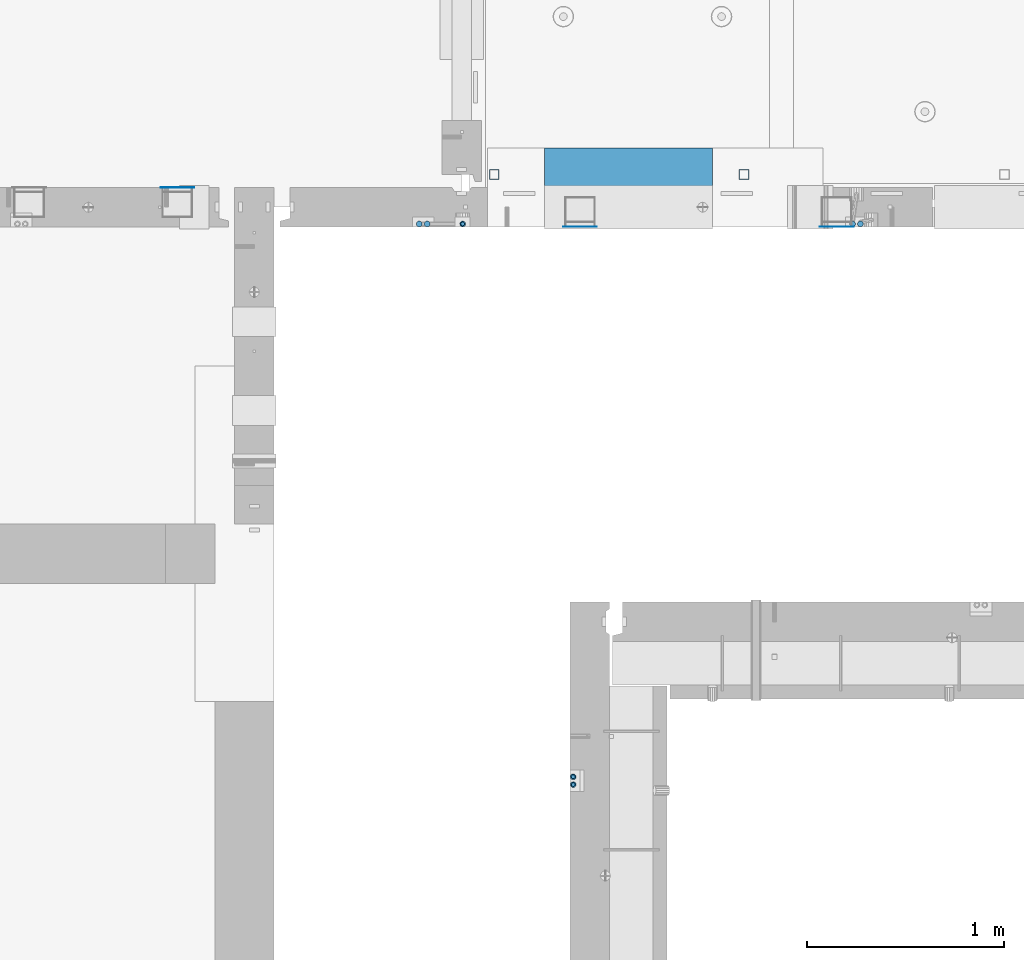
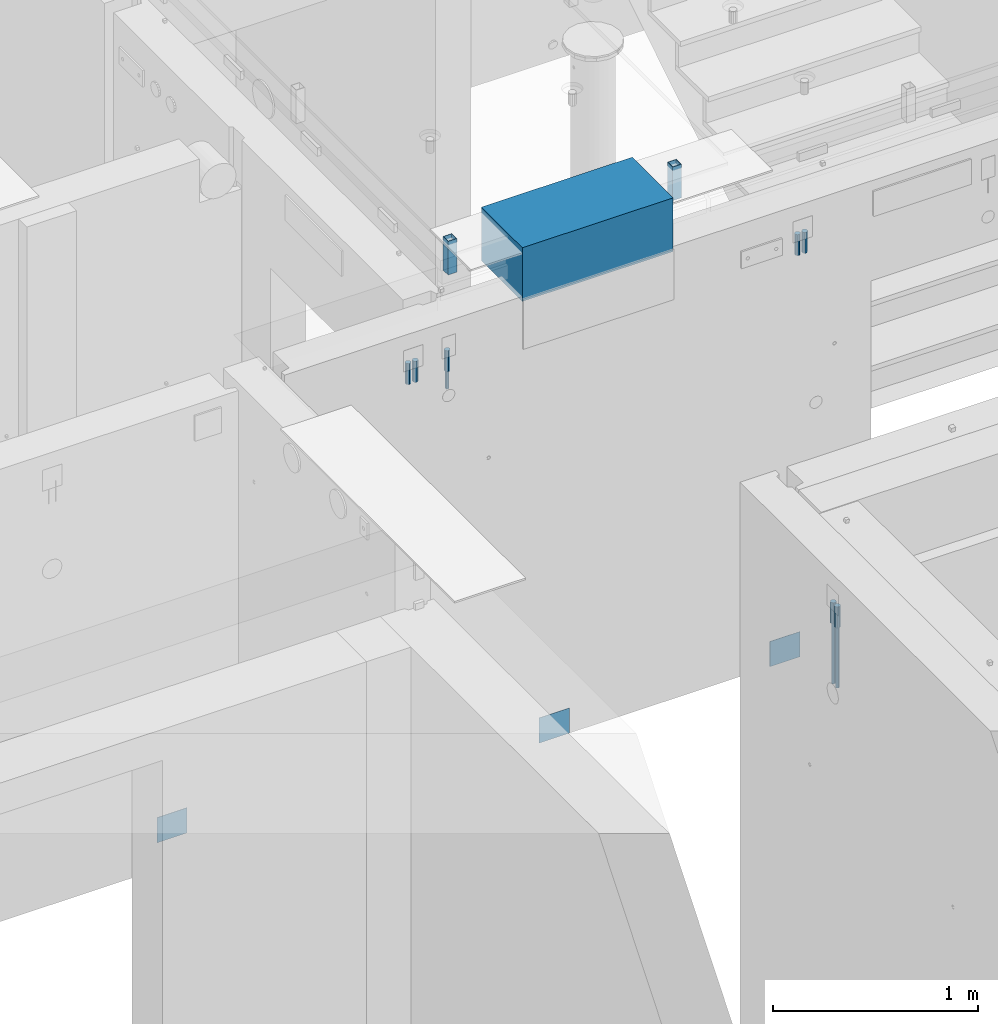
# One storey, part 8 of 264: 16 columns, 10 elements without a shape of their own.
"""IFC2X3 building model written with IfcOpenShell, lengths in millimetres."""

from ifc_helpers import new_model, si_unit, frame, origin_with_axes, place, context, subcontext, project, spatial, faceted_brep, material, type_object, element, aggregate, save


model = new_model("IFC2X3")

# Units and contexts
model_context = context("Model", 3, precision=1e-05, world=origin_with_axes())
body_context = subcontext(model_context, "Body", "Model", "MODEL_VIEW")
ifc_project = project(units=[si_unit("LENGTHUNIT", "METRE", prefix="MILLI"), si_unit("AREAUNIT", "SQUARE_METRE"), si_unit("VOLUMEUNIT", "CUBIC_METRE"), si_unit("MASSUNIT", "GRAM", prefix="KILO"), si_unit("TIMEUNIT", "SECOND"), si_unit("PLANEANGLEUNIT", "RADIAN"), si_unit("SOLIDANGLEUNIT", "STERADIAN"), si_unit("THERMODYNAMICTEMPERATUREUNIT", "DEGREE_CELSIUS"), si_unit("LUMINOUSINTENSITYUNIT", "LUMEN")], contexts=[model_context])

# Site, building, storey
site_placement = place(None, origin_with_axes())
site = spatial("IfcSite", under=ifc_project, at=site_placement, CompositionType="ELEMENT")
building_placement = place(site_placement, origin_with_axes())
building = spatial("IfcBuilding", under=site, at=building_placement, CompositionType="ELEMENT")
storey_placement = place(building_placement, origin_with_axes())
storey = spatial("IfcBuildingStorey", under=building, at=storey_placement, Name="K", CompositionType="ELEMENT", Elevation=0.0)

# Assembly, columns
assembly_1_placement = place(storey_placement, origin_with_axes())
assembly_1 = element("IfcElementAssembly", 1, at=assembly_1_placement, inside=storey, AssemblyPlace="NOTDEFINED", PredefinedType="REINFORCEMENT_UNIT")
ifc_material_1 = material()
column_type_1 = type_object("IfcColumnType", Name="D30", PredefinedType="NOTDEFINED")
column_1_placement = place(assembly_1_placement, frame((19730.0015915468, 15095.0, 81167.5), z_axis=(0.0, 1.0, 0.0), x_axis=(0.0, 0.0, 1.0)))
column_1 = element("IfcColumn", 2, at=column_1_placement, type_object=column_type_1, material=ifc_material_1, ObjectType="D30", context=body_context, shape_type="Brep", body=[
    faceted_brep([(0.0, -15.0, 0.0), (0.0, -12.9903810567666, -7.5), (125.0, -12.9903810567666, -7.5), (125.0, -15.0, 0.0), (0.0, -7.5, -12.9903810567666), (125.0, -7.5, -12.9903810567666), (0.0, 0.0, -15.0), (125.0, 0.0, -15.0), (0.0, 7.5, -12.9903810567666), (125.0, 7.5, -12.9903810567666), (0.0, 12.9903810567666, -7.5), (125.0, 12.9903810567666, -7.5), (0.0, 15.0, 0.0), (125.0, 15.0, 0.0), (0.0, 12.9903810567666, 7.5), (125.0, 12.9903810567666, 7.5), (0.0, 7.5, 12.9903810567666), (125.0, 7.5, 12.9903810567666), (0.0, 0.0, 15.0), (125.0, 0.0, 15.0), (0.0, -7.5, 12.9903810567666), (125.0, -7.5, 12.9903810567666), (0.0, -12.9903810567666, 7.5), (125.0, -12.9903810567666, 7.5)], [[[0, 1, 2, 3]], [[1, 4, 5, 2]], [[4, 6, 7, 5]], [[6, 8, 9, 7]], [[8, 10, 11, 9]], [[10, 12, 13, 11]], [[12, 14, 15, 13]], [[14, 16, 17, 15]], [[16, 18, 19, 17]], [[18, 20, 21, 19]], [[20, 22, 23, 21]], [[22, 0, 3, 23]], [[5, 7, 9, 11, 13, 15, 17, 19, 21, 23, 3, 2]], [[22, 20, 18, 16, 14, 12, 10, 8, 6, 4, 1, 0]]]),
])
column_2_placement = place(assembly_1_placement, frame((19690.0015915468, 15095.0, 81167.5), z_axis=(0.0, 1.0, 0.0), x_axis=(0.0, 0.0, 1.0)))
column_2 = element("IfcColumn", 3, at=column_2_placement, type_object=column_type_1, material=ifc_material_1, ObjectType="D30", context=body_context, shape_type="Brep", body=[
    faceted_brep([(0.0, -15.0, 0.0), (0.0, -12.9903810567666, -7.5), (125.0, -12.9903810567666, -7.5), (125.0, -15.0, 0.0), (0.0, -7.5, -12.9903810567666), (125.0, -7.5, -12.9903810567666), (0.0, 0.0, -15.0), (125.0, 0.0, -15.0), (0.0, 7.5, -12.9903810567666), (125.0, 7.5, -12.9903810567666), (0.0, 12.9903810567666, -7.5), (125.0, 12.9903810567666, -7.5), (0.0, 15.0, 0.0), (125.0, 15.0, 0.0), (0.0, 12.9903810567666, 7.5), (125.0, 12.9903810567666, 7.5), (0.0, 7.5, 12.9903810567666), (125.0, 7.5, 12.9903810567666), (0.0, 0.0, 15.0), (125.0, 0.0, 15.0), (0.0, -7.5, 12.9903810567666), (125.0, -7.5, 12.9903810567666), (0.0, -12.9903810567666, 7.5), (125.0, -12.9903810567666, 7.5)], [[[0, 1, 2, 3]], [[1, 4, 5, 2]], [[4, 6, 7, 5]], [[6, 8, 9, 7]], [[8, 10, 11, 9]], [[10, 12, 13, 11]], [[12, 14, 15, 13]], [[14, 16, 17, 15]], [[16, 18, 19, 17]], [[18, 20, 21, 19]], [[20, 22, 23, 21]], [[22, 0, 3, 23]], [[5, 7, 9, 11, 13, 15, 17, 19, 21, 23, 3, 2]], [[22, 20, 18, 16, 14, 12, 10, 8, 6, 4, 1, 0]]]),
])
column_3_placement = place(assembly_1_placement, frame((17715.0015915468, 15095.0, 81167.5), z_axis=(0.0, 1.0, 0.0), x_axis=(0.0, 0.0, 1.0)))
column_3 = element("IfcColumn", 4, at=column_3_placement, type_object=column_type_1, material=ifc_material_1, ObjectType="D30", context=body_context, shape_type="Brep", body=[
    faceted_brep([(0.0, -15.0, 0.0), (0.0, -12.9903810567666, -7.5), (125.0, -12.9903810567666, -7.5), (125.0, -15.0, 0.0), (0.0, -7.5, -12.9903810567666), (125.0, -7.5, -12.9903810567666), (0.0, 0.0, -15.0), (125.0, 0.0, -15.0), (0.0, 7.5, -12.9903810567666), (125.0, 7.5, -12.9903810567666), (0.0, 12.9903810567666, -7.5), (125.0, 12.9903810567666, -7.5), (0.0, 15.0, 0.0), (125.0, 15.0, 0.0), (0.0, 12.9903810567666, 7.5), (125.0, 12.9903810567666, 7.5), (0.0, 7.5, 12.9903810567666), (125.0, 7.5, 12.9903810567666), (0.0, 0.0, 15.0), (125.0, 0.0, 15.0), (0.0, -7.5, 12.9903810567666), (125.0, -7.5, 12.9903810567666), (0.0, -12.9903810567666, 7.5), (125.0, -12.9903810567666, 7.5)], [[[0, 1, 2, 3]], [[1, 4, 5, 2]], [[4, 6, 7, 5]], [[6, 8, 9, 7]], [[8, 10, 11, 9]], [[10, 12, 13, 11]], [[12, 14, 15, 13]], [[14, 16, 17, 15]], [[16, 18, 19, 17]], [[18, 20, 21, 19]], [[20, 22, 23, 21]], [[22, 0, 3, 23]], [[5, 7, 9, 11, 13, 15, 17, 19, 21, 23, 3, 2]], [[22, 20, 18, 16, 14, 12, 10, 8, 6, 4, 1, 0]]]),
])
column_4_placement = place(assembly_1_placement, frame((17535.0015915468, 15095.0, 81167.5), z_axis=(0.0, 1.0, 0.0), x_axis=(0.0, 0.0, 1.0)))
column_4 = element("IfcColumn", 5, at=column_4_placement, type_object=column_type_1, material=ifc_material_1, ObjectType="D30", context=body_context, shape_type="Brep", body=[
    faceted_brep([(0.0, -15.0, 0.0), (0.0, -12.9903810567666, -7.5), (125.0, -12.9903810567666, -7.5), (125.0, -15.0, 0.0), (0.0, -7.5, -12.9903810567666), (125.0, -7.5, -12.9903810567666), (0.0, 0.0, -15.0), (125.0, 0.0, -15.0), (0.0, 7.5, -12.9903810567666), (125.0, 7.5, -12.9903810567666), (0.0, 12.9903810567666, -7.5), (125.0, 12.9903810567666, -7.5), (0.0, 15.0, 0.0), (125.0, 15.0, 0.0), (0.0, 12.9903810567666, 7.5), (125.0, 12.9903810567666, 7.5), (0.0, 7.5, 12.9903810567666), (125.0, 7.5, 12.9903810567666), (0.0, 0.0, 15.0), (125.0, 0.0, 15.0), (0.0, -7.5, 12.9903810567666), (125.0, -7.5, 12.9903810567666), (0.0, -12.9903810567666, 7.5), (125.0, -12.9903810567666, 7.5)], [[[0, 1, 2, 3]], [[1, 4, 5, 2]], [[4, 6, 7, 5]], [[6, 8, 9, 7]], [[8, 10, 11, 9]], [[10, 12, 13, 11]], [[12, 14, 15, 13]], [[14, 16, 17, 15]], [[16, 18, 19, 17]], [[18, 20, 21, 19]], [[20, 22, 23, 21]], [[22, 0, 3, 23]], [[5, 7, 9, 11, 13, 15, 17, 19, 21, 23, 3, 2]], [[22, 20, 18, 16, 14, 12, 10, 8, 6, 4, 1, 0]]]),
])
column_5_placement = place(assembly_1_placement, frame((17495.0015915468, 15095.0, 81167.5), z_axis=(0.0, 1.0, 0.0), x_axis=(0.0, 0.0, 1.0)))
column_5 = element("IfcColumn", 6, at=column_5_placement, type_object=column_type_1, material=ifc_material_1, ObjectType="D30", context=body_context, shape_type="Brep", body=[
    faceted_brep([(0.0, -15.0, 0.0), (0.0, -12.9903810567666, -7.5), (125.0, -12.9903810567666, -7.5), (125.0, -15.0, 0.0), (0.0, -7.5, -12.9903810567666), (125.0, -7.5, -12.9903810567666), (0.0, 0.0, -15.0), (125.0, 0.0, -15.0), (0.0, 7.5, -12.9903810567666), (125.0, 7.5, -12.9903810567666), (0.0, 12.9903810567666, -7.5), (125.0, 12.9903810567666, -7.5), (0.0, 15.0, 0.0), (125.0, 15.0, 0.0), (0.0, 12.9903810567666, 7.5), (125.0, 12.9903810567666, 7.5), (0.0, 7.5, 12.9903810567666), (125.0, 7.5, 12.9903810567666), (0.0, 0.0, 15.0), (125.0, 0.0, 15.0), (0.0, -7.5, 12.9903810567666), (125.0, -7.5, 12.9903810567666), (0.0, -12.9903810567666, 7.5), (125.0, -12.9903810567666, 7.5)], [[[0, 1, 2, 3]], [[1, 4, 5, 2]], [[4, 6, 7, 5]], [[6, 8, 9, 7]], [[8, 10, 11, 9]], [[10, 12, 13, 11]], [[12, 14, 15, 13]], [[14, 16, 17, 15]], [[16, 18, 19, 17]], [[18, 20, 21, 19]], [[20, 22, 23, 21]], [[22, 0, 3, 23]], [[5, 7, 9, 11, 13, 15, 17, 19, 21, 23, 3, 2]], [[22, 20, 18, 16, 14, 12, 10, 8, 6, 4, 1, 0]]]),
])

assembly_2_placement = place(storey_placement, origin_with_axes())
assembly_2 = element("IfcElementAssembly", 7, at=assembly_2_placement, inside=storey, AssemblyPlace="NOTDEFINED", PredefinedType="REINFORCEMENT_UNIT")
column_6_placement = place(assembly_2_placement, frame((18275.0, 12255.000305038, 81167.5), z_axis=(1.0, 0.0, 0.0), x_axis=(0.0, 0.0, 1.0)))
column_6 = element("IfcColumn", 8, at=column_6_placement, type_object=column_type_1, material=ifc_material_1, ObjectType="D30", context=body_context, shape_type="Brep", body=[
    faceted_brep([(0.0, -15.0, 0.0), (0.0, -12.9903810567666, -7.5), (125.0, -12.9903810567666, -7.5), (125.0, -15.0, 0.0), (0.0, -7.5, -12.9903810567666), (125.0, -7.5, -12.9903810567666), (0.0, 0.0, -15.0), (125.0, 0.0, -15.0), (0.0, 7.5, -12.9903810567666), (125.0, 7.5, -12.9903810567666), (0.0, 12.9903810567666, -7.5), (125.0, 12.9903810567666, -7.5), (0.0, 15.0, 0.0), (125.0, 15.0, 0.0), (0.0, 12.9903810567666, 7.5), (125.0, 12.9903810567666, 7.5), (0.0, 7.5, 12.9903810567666), (125.0, 7.5, 12.9903810567666), (0.0, 0.0, 15.0), (125.0, 0.0, 15.0), (0.0, -7.5, 12.9903810567666), (125.0, -7.5, 12.9903810567666), (0.0, -12.9903810567666, 7.5), (125.0, -12.9903810567666, 7.5)], [[[0, 1, 2, 3]], [[1, 4, 5, 2]], [[4, 6, 7, 5]], [[6, 8, 9, 7]], [[8, 10, 11, 9]], [[10, 12, 13, 11]], [[12, 14, 15, 13]], [[14, 16, 17, 15]], [[16, 18, 19, 17]], [[18, 20, 21, 19]], [[20, 22, 23, 21]], [[22, 0, 3, 23]], [[5, 7, 9, 11, 13, 15, 17, 19, 21, 23, 3, 2]], [[22, 20, 18, 16, 14, 12, 10, 8, 6, 4, 1, 0]]]),
])
column_7_placement = place(assembly_2_placement, frame((18275.0, 12295.000305038, 81167.5), z_axis=(1.0, 0.0, 0.0), x_axis=(0.0, 0.0, 1.0)))
column_7 = element("IfcColumn", 9, at=column_7_placement, type_object=column_type_1, material=ifc_material_1, ObjectType="D30", context=body_context, shape_type="Brep", body=[
    faceted_brep([(0.0, -15.0, 0.0), (0.0, -12.9903810567666, -7.5), (125.0, -12.9903810567666, -7.5), (125.0, -15.0, 0.0), (0.0, -7.5, -12.9903810567666), (125.0, -7.5, -12.9903810567666), (0.0, 0.0, -15.0), (125.0, 0.0, -15.0), (0.0, 7.5, -12.9903810567666), (125.0, 7.5, -12.9903810567666), (0.0, 12.9903810567666, -7.5), (125.0, 12.9903810567666, -7.5), (0.0, 15.0, 0.0), (125.0, 15.0, 0.0), (0.0, 12.9903810567666, 7.5), (125.0, 12.9903810567666, 7.5), (0.0, 7.5, 12.9903810567666), (125.0, 7.5, 12.9903810567666), (0.0, 0.0, 15.0), (125.0, 0.0, 15.0), (0.0, -7.5, 12.9903810567666), (125.0, -7.5, 12.9903810567666), (0.0, -12.9903810567666, 7.5), (125.0, -12.9903810567666, 7.5)], [[[0, 1, 2, 3]], [[1, 4, 5, 2]], [[4, 6, 7, 5]], [[6, 8, 9, 7]], [[8, 10, 11, 9]], [[10, 12, 13, 11]], [[12, 14, 15, 13]], [[14, 16, 17, 15]], [[16, 18, 19, 17]], [[18, 20, 21, 19]], [[20, 22, 23, 21]], [[22, 0, 3, 23]], [[5, 7, 9, 11, 13, 15, 17, 19, 21, 23, 3, 2]], [[22, 20, 18, 16, 14, 12, 10, 8, 6, 4, 1, 0]]]),
])

# Assembly, column
assembly_3_placement = place(assembly_1_placement, origin_with_axes())
assembly_3 = element("IfcElementAssembly", 10, at=assembly_3_placement, Name="Steel Assembly", AssemblyPlace="NOTDEFINED", PredefinedType="NOTDEFINED")
ifc_material_2 = material(Name="Undefined")
column_type_2 = type_object("IfcColumnType", PredefinedType="NOTDEFINED")
column_8_placement = place(assembly_3_placement, frame((18309.9991455078, 15080.9999974657, 78775.0000025593), z_axis=(0.0, -1.0, 0.0), x_axis=(0.0, 0.0, 1.0)))
column_8 = element("IfcColumn", 11, at=column_8_placement, type_object=column_type_2, material=ifc_material_2, Name="SPK3", context=body_context, shape_type="Brep", body=[
    faceted_brep([(0.0, 85.0, -1.0), (0.0, 85.0, 1.0), (150.0, 85.0, 1.0), (150.0, 85.0, -1.0), (0.0, -85.0, 1.0), (150.0, -85.0, 1.0), (0.0, -85.0, -1.0), (150.0, -85.0, -1.0)], [[[0, 1, 2, 3]], [[1, 4, 5, 2]], [[4, 6, 7, 5]], [[6, 0, 3, 7]], [[5, 7, 3, 2]], [[6, 4, 1, 0]]]),
])
aggregate(assembly_3, [column_8])

# Assemblies, column
assembly_4_placement = place(storey_placement, origin_with_axes())
assembly_4 = element("IfcElementAssembly", 12, at=assembly_4_placement, inside=storey, AssemblyPlace="NOTDEFINED", PredefinedType="REINFORCEMENT_UNIT")
assembly_5_placement = place(assembly_4_placement, origin_with_axes())
assembly_5 = element("IfcElementAssembly", 13, at=assembly_5_placement, Name="Steel Assembly", AssemblyPlace="NOTDEFINED", PredefinedType="NOTDEFINED")
aggregate(assembly_4, [assembly_5])
column_9_placement = place(assembly_5_placement, frame((16270.0012172342, 15279.0002441207, 78775.1200050936), z_axis=(0.0, 1.0, 0.0), x_axis=(0.0, 0.0, 1.0)))
column_9 = element("IfcColumn", 14, at=column_9_placement, type_object=column_type_2, material=ifc_material_2, Name="SPK3", context=body_context, shape_type="Brep", body=[
    faceted_brep([(0.0, 85.0, -1.0), (0.0, 85.0, 1.0), (150.0, 85.0, 1.0), (150.0, 85.0, -1.0), (0.0, -85.0, 1.0), (150.0, -85.0, 1.0), (0.0, -85.0, -1.0), (150.0, -85.0, -1.0)], [[[0, 1, 2, 3]], [[1, 4, 5, 2]], [[4, 6, 7, 5]], [[6, 0, 3, 7]], [[5, 7, 3, 2]], [[6, 4, 1, 0]]]),
])
aggregate(assembly_5, [column_9])

# Assembly, column
assembly_6_placement = place(assembly_1_placement, origin_with_axes())
assembly_6 = element("IfcElementAssembly", 15, at=assembly_6_placement, Name="Steel Assembly", AssemblyPlace="NOTDEFINED", PredefinedType="NOTDEFINED")
column_10_placement = place(assembly_6_placement, frame((19609.9991455078, 15080.9999974657, 78775.0000025593), z_axis=(0.0, -1.0, 0.0), x_axis=(0.0, 0.0, 1.0)))
column_10 = element("IfcColumn", 16, at=column_10_placement, type_object=column_type_2, material=ifc_material_2, Name="SPK3", context=body_context, shape_type="Brep", body=[
    faceted_brep([(0.0, 85.0, -1.0), (0.0, 85.0, 1.0), (150.0, 85.0, 1.0), (150.0, 85.0, -1.0), (0.0, -85.0, 1.0), (150.0, -85.0, 1.0), (0.0, -85.0, -1.0), (150.0, -85.0, -1.0)], [[[0, 1, 2, 3]], [[1, 4, 5, 2]], [[4, 6, 7, 5]], [[6, 0, 3, 7]], [[5, 7, 3, 2]], [[6, 4, 1, 0]]]),
])
aggregate(assembly_6, [column_10])

# Assemblies, columns
assembly_7_placement = place(storey_placement, origin_with_axes())
assembly_7 = element("IfcElementAssembly", 17, at=assembly_7_placement, inside=storey, AssemblyPlace="NOTDEFINED", PredefinedType="REINFORCEMENT_UNIT")
assembly_8_placement = place(assembly_7_placement, origin_with_axes())
assembly_8 = element("IfcElementAssembly", 18, at=assembly_8_placement, Name="Steel Assembly", AssemblyPlace="NOTDEFINED", PredefinedType="RIGID_FRAME")
ifc_material_3 = material(Name="STEEL/S355J2")
column_type_3 = type_object("IfcColumnType", Name="50X50X3", PredefinedType="NOTDEFINED")
column_11_placement = place(assembly_8_placement, frame((17875.0159390845, 15345.0026483099, 81550.0), z_axis=(-1.0, 3.00000001838171e-08, 0.0), x_axis=(0.0, 0.0, 1.0)))
column_11 = element("IfcColumn", 19, at=column_11_placement, type_object=column_type_3, material=ifc_material_3, ObjectType="50X50X3", context=body_context, shape_type="Brep", body=[
    faceted_brep([(0.0, 22.0, -22.0), (0.0, -22.0, -22.0), (200.0, -22.0, -22.0), (200.0, 22.0, -22.0), (0.0, -22.0, 22.0), (200.0, -22.0, 22.0), (0.0, 22.0, 22.0), (200.0, 22.0, 22.0), (0.0, 25.0, -25.0), (0.0, 25.0, 25.0), (200.0, 25.0, 25.0), (200.0, 25.0, -25.0), (0.0, -25.0, 25.0), (200.0, -25.0, 25.0), (0.0, -25.0, -25.0), (200.0, -25.0, -25.0)], [[[0, 1, 2, 3]], [[1, 4, 5, 2]], [[4, 6, 7, 5]], [[6, 0, 3, 7]], [[8, 9, 10, 11]], [[9, 12, 13, 10]], [[12, 14, 15, 13]], [[14, 8, 11, 15]], [[13, 15, 11, 10], [5, 7, 3, 2]], [[14, 12, 9, 8], [6, 4, 1, 0]]]),
])
aggregate(assembly_8, [column_11])
assembly_9_placement = place(assembly_7_placement, origin_with_axes())
assembly_9 = element("IfcElementAssembly", 20, at=assembly_9_placement, Name="Steel Assembly", AssemblyPlace="NOTDEFINED", PredefinedType="RIGID_FRAME")
aggregate(assembly_7, [assembly_8, assembly_9])
column_12_placement = place(assembly_9_placement, frame((19140.0159390845, 15345.0026483099, 81550.0), z_axis=(-1.0, 3.00000001838171e-08, 0.0), x_axis=(0.0, 0.0, 1.0)))
column_12 = element("IfcColumn", 21, at=column_12_placement, type_object=column_type_3, material=ifc_material_3, ObjectType="50X50X3", context=body_context, shape_type="Brep", body=[
    faceted_brep([(0.0, 22.0, -22.0), (0.0, -22.0, -22.0), (200.0, -22.0, -22.0), (200.0, 22.0, -22.0), (0.0, -22.0, 22.0), (200.0, -22.0, 22.0), (0.0, 22.0, 22.0), (200.0, 22.0, 22.0), (0.0, 25.0, -25.0), (0.0, 25.0, 25.0), (200.0, 25.0, 25.0), (200.0, 25.0, -25.0), (0.0, -25.0, 25.0), (200.0, -25.0, 25.0), (0.0, -25.0, -25.0), (200.0, -25.0, -25.0)], [[[0, 1, 2, 3]], [[1, 4, 5, 2]], [[4, 6, 7, 5]], [[6, 0, 3, 7]], [[8, 9, 10, 11]], [[9, 12, 13, 10]], [[12, 14, 15, 13]], [[14, 8, 11, 15]], [[13, 15, 11, 10], [5, 7, 3, 2]], [[14, 12, 9, 8], [6, 4, 1, 0]]]),
])
aggregate(assembly_9, [column_12])

# Column
column_type_4 = type_object("IfcColumnType", Name="D20", PredefinedType="NOTDEFINED")
column_13_placement = place(assembly_1_placement, frame((17715.0015915473, 15095.0, 81060.0), z_axis=(0.0, 1.0, 0.0), x_axis=(0.0, 0.0, 1.0)))
column_13 = element("IfcColumn", 22, at=column_13_placement, type_object=column_type_4, material=ifc_material_1, Name="JM20", ObjectType="D20", context=body_context, shape_type="Brep", body=[
    faceted_brep([(0.0, -10.0, 0.0), (-4.19531716033816e-08, -7.07106781186667, -7.07106781187031), (107.499999999141, -7.07106781186667, -7.07106781186485), (107.499999999141, -10.0, 0.0), (0.0, 0.0, -10.0), (107.499999999141, 0.0, -10.0), (4.196772351861e-08, 7.07106781186303, -7.07106781186667), (107.499999999141, 7.07106781186667, -7.07106781186485), (0.0, 10.0, 0.0), (107.499999999141, 10.0, 0.0), (4.196772351861e-08, 7.07106781185939, 7.07106781185939), (107.499999999141, 7.07106781186667, 7.07106781186485), (0.0, 0.0, 10.0), (107.499999999141, 0.0, 10.0), (-4.19531716033816e-08, -7.07106781187031, 7.07106781185939), (107.499999999141, -7.07106781186667, 7.07106781186485)], [[[0, 1, 2, 3]], [[1, 4, 5, 2]], [[4, 6, 7, 5]], [[6, 8, 9, 7]], [[8, 10, 11, 9]], [[10, 12, 13, 11]], [[12, 14, 15, 13]], [[14, 0, 3, 15]], [[5, 7, 9, 11, 13, 15, 3, 2]], [[14, 12, 10, 8, 6, 4, 1, 0]]]),
])

aggregate(assembly_1, [column_1, column_2, column_13, column_3, column_4, column_5, assembly_3, assembly_6])

column_14_placement = place(assembly_2_placement, frame((18275.0, 12255.0003050374, 80805.0), z_axis=(1.0, 0.0, 0.0), x_axis=(0.0, 0.0, 1.0)))
column_14 = element("IfcColumn", 23, at=column_14_placement, type_object=column_type_4, material=ifc_material_1, Name="JM20", ObjectType="D20", context=body_context, shape_type="Brep", body=[
    faceted_brep([(0.0, -10.0, 0.0), (-4.19531716033816e-08, -7.07106781186667, -7.07106781187031), (362.5, -7.07106781186667, -7.07106781186485), (362.5, -10.0, 0.0), (0.0, 0.0, -10.0), (362.5, 0.0, -10.0), (4.196772351861e-08, 7.07106781186303, -7.07106781186667), (362.5, 7.07106781186667, -7.07106781186485), (0.0, 10.0, 0.0), (362.5, 10.0, 0.0), (4.196772351861e-08, 7.07106781185939, 7.07106781185939), (362.5, 7.07106781186667, 7.07106781186485), (0.0, 0.0, 10.0), (362.5, 0.0, 10.0), (-4.19531716033816e-08, -7.07106781187031, 7.07106781185939), (362.5, -7.07106781186667, 7.07106781186485)], [[[0, 1, 2, 3]], [[1, 4, 5, 2]], [[4, 6, 7, 5]], [[6, 8, 9, 7]], [[8, 10, 11, 9]], [[10, 12, 13, 11]], [[12, 14, 15, 13]], [[14, 0, 3, 15]], [[5, 7, 9, 11, 13, 15, 3, 2]], [[14, 12, 10, 8, 6, 4, 1, 0]]]),
])

column_15_placement = place(assembly_2_placement, frame((18275.0, 12295.0003050374, 80805.0), z_axis=(1.0, 0.0, 0.0), x_axis=(0.0, 0.0, 1.0)))
column_15 = element("IfcColumn", 24, at=column_15_placement, type_object=column_type_4, material=ifc_material_1, Name="JM20", ObjectType="D20", context=body_context, shape_type="Brep", body=[
    faceted_brep([(0.0, -10.0, 0.0), (-4.19531716033816e-08, -7.07106781186667, -7.07106781187031), (362.5, -7.07106781186667, -7.07106781186485), (362.5, -10.0, 0.0), (0.0, 0.0, -10.0), (362.5, 0.0, -10.0), (4.196772351861e-08, 7.07106781186303, -7.07106781186667), (362.5, 7.07106781186667, -7.07106781186485), (0.0, 10.0, 0.0), (362.5, 10.0, 0.0), (4.196772351861e-08, 7.07106781185939, 7.07106781185939), (362.5, 7.07106781186667, 7.07106781186485), (0.0, 0.0, 10.0), (362.5, 0.0, 10.0), (-4.19531716033816e-08, -7.07106781187031, 7.07106781185939), (362.5, -7.07106781186667, 7.07106781186485)], [[[0, 1, 2, 3]], [[1, 4, 5, 2]], [[4, 6, 7, 5]], [[6, 8, 9, 7]], [[8, 10, 11, 9]], [[10, 12, 13, 11]], [[12, 14, 15, 13]], [[14, 0, 3, 15]], [[5, 7, 9, 11, 13, 15, 3, 2]], [[14, 12, 10, 8, 6, 4, 1, 0]]]),
])

aggregate(assembly_2, [column_14, column_6, column_15, column_7])

# Assembly, column
assembly_10_placement = place(storey_placement, origin_with_axes())
assembly_10 = element("IfcElementAssembly", 25, at=assembly_10_placement, inside=storey, Name="Steel Assembly", AssemblyPlace="NOTDEFINED", PredefinedType="NOTDEFINED")
ifc_material_4 = material()
column_type_5 = type_object("IfcColumnType", PredefinedType="NOTDEFINED")
column_16_placement = place(assembly_10_placement, frame((18554.999845922, 15279.9995407462, 81440.0), z_axis=(0.0, 1.0, 0.0), x_axis=(0.0, 0.0, 1.0)))
column_16 = element("IfcColumn", 26, at=column_16_placement, type_object=column_type_5, material=ifc_material_4, context=body_context, shape_type="Brep", body=[
    faceted_brep([(0.0, 425.0, -200.0), (0.0, 425.0, 200.0), (320.0, 425.0, 200.0), (320.0, 425.0, -200.0), (0.0, -425.0, 200.0), (320.0, -425.0, 200.0), (0.0, -425.0, -200.0), (320.0, -425.0, -200.0)], [[[0, 1, 2, 3]], [[1, 4, 5, 2]], [[4, 6, 7, 5]], [[6, 0, 3, 7]], [[5, 7, 3, 2]], [[6, 4, 1, 0]]]),
])
aggregate(assembly_10, [column_16])

save(model, "model.ifc")
